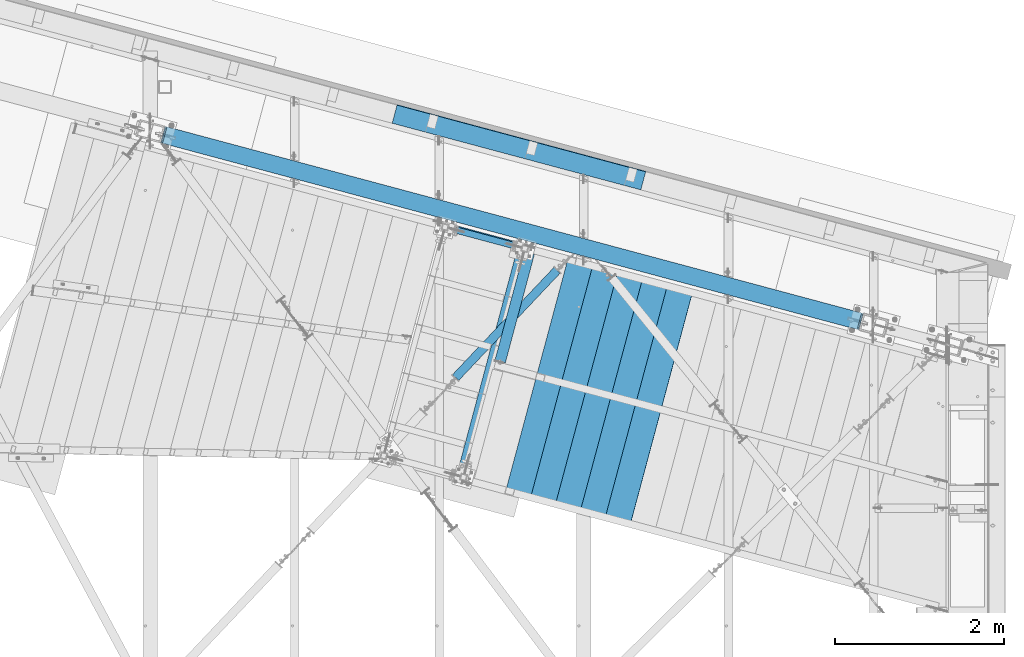
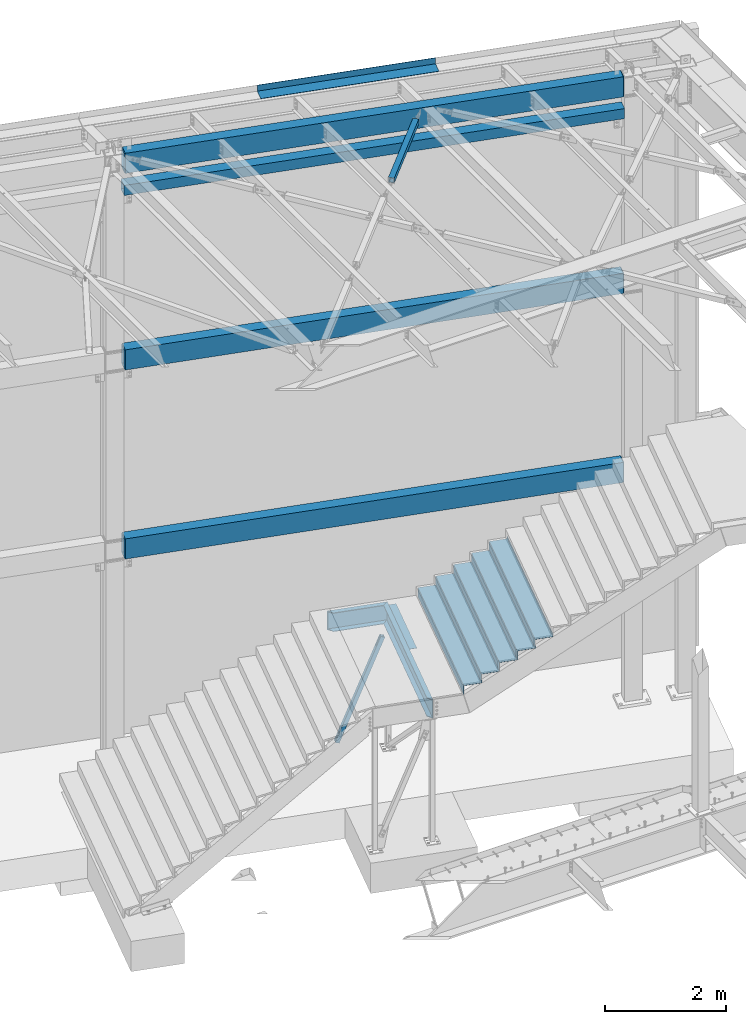
# One storey, part 1174 of 1763: 14 beams, 1 member, 9 elements without a shape of their own.
"""IFC2X3 building model written with IfcOpenShell, lengths in millimetres."""

from ifc_helpers import new_model, si_unit, frame, origin_with_axes, place, context, subcontext, project, spatial, faceted_brep, material, type_object, element, aggregate, save


model = new_model("IFC2X3")

# Units and contexts
model_context = context("Model", 3, precision=1e-05, world=origin_with_axes())
body_context = subcontext(model_context, "Body", "Model", "MODEL_VIEW")
ifc_project = project(units=[si_unit("LENGTHUNIT", "METRE", prefix="MILLI"), si_unit("AREAUNIT", "SQUARE_METRE"), si_unit("VOLUMEUNIT", "CUBIC_METRE"), si_unit("MASSUNIT", "GRAM", prefix="KILO"), si_unit("TIMEUNIT", "SECOND"), si_unit("PLANEANGLEUNIT", "RADIAN"), si_unit("SOLIDANGLEUNIT", "STERADIAN"), si_unit("THERMODYNAMICTEMPERATUREUNIT", "DEGREE_CELSIUS"), si_unit("LUMINOUSINTENSITYUNIT", "LUMEN")], contexts=[model_context])

# Site, building, storey
site_placement = place(None, origin_with_axes())
site = spatial("IfcSite", under=ifc_project, at=site_placement, CompositionType="ELEMENT")
building_placement = place(site_placement, origin_with_axes())
building = spatial("IfcBuilding", under=site, at=building_placement, Name="Undefined", CompositionType="ELEMENT")
storey_placement = place(building_placement, origin_with_axes())
storey = spatial("IfcBuildingStorey", under=building, at=storey_placement, Name="Undefined", CompositionType="ELEMENT", Elevation=0.0)

# Assembly, beam
assembly_1_placement = place(storey_placement, origin_with_axes())
assembly_1 = element("IfcElementAssembly", 1, at=assembly_1_placement, inside=storey, Name="BEAM", AssemblyPlace="NOTDEFINED", PredefinedType="RIGID_FRAME")
ifc_material_1 = material()
beam_type_1 = type_object("IfcBeamType", Name="HSS8X8X3/8", PredefinedType="NOTDEFINED")
beam_1_placement = place(assembly_1_placement, frame((-31109.3096174142, 64386.9589945275, 11699.875), z_axis=(0.0, 0.0, 1.0), x_axis=(0.965925826295336, -0.25881904507913, 0.0)))
beam_1 = element("IfcBeam", 2, at=beam_1_placement, type_object=beam_type_1, material=ifc_material_1, Name="BEAM", ObjectType="HSS8X8X3/8", context=body_context, shape_type="Brep", body=[
    faceted_brep([(152.404929528384, 92.0750000005864, -92.0750000000007), (152.404929527896, -92.0749999999898, -92.0750000000007), (8712.52908409735, -92.0749999837644, -92.0750000000007), (8712.52908409783, 92.0750000168191, -92.0750000000007), (152.404929527896, -92.0749999999898, 92.0750000000007), (8712.52908409735, -92.0749999837644, 92.0750000000007), (152.404929528384, 92.0750000005864, 92.0750000000007), (8712.52908409783, 92.0750000168191, 92.0750000000007), (152.404929528398, 101.600000000624, -101.6), (152.404929528398, 101.600000000624, 101.6), (8712.52908409786, 101.600000016842, 101.6), (8712.52908409786, 101.600000016842, -101.6), (152.404929527875, -101.60000000002, 101.6), (8712.52908409732, -101.59999998378, 101.6), (152.404929527875, -101.60000000002, -101.6), (8712.52908409732, -101.59999998378, -101.6)], [[[0, 1, 2, 3]], [[1, 4, 5, 2]], [[4, 6, 7, 5]], [[6, 0, 3, 7]], [[8, 9, 10, 11]], [[9, 12, 13, 10]], [[12, 14, 15, 13]], [[14, 8, 11, 15]], [[13, 15, 11, 10], [5, 7, 3, 2]], [[14, 12, 9, 8], [6, 4, 1, 0]]]),
])
aggregate(assembly_1, [beam_1])

assembly_2_placement = place(storey_placement, origin_with_axes())
assembly_2 = element("IfcElementAssembly", 3, at=assembly_2_placement, inside=storey, Name="BEAM", AssemblyPlace="NOTDEFINED", PredefinedType="RIGID_FRAME")
beam_type_2 = type_object("IfcBeamType", Name="HSS16X8X5/8", PredefinedType="NOTDEFINED")
beam_2_placement = place(assembly_2_placement, frame((-31109.3096174048, 64386.9589945249, 4470.4), z_axis=(0.0, 0.0, 1.0), x_axis=(0.965925826295336, -0.25881904507913, 0.0)))
beam_2 = element("IfcBeam", 4, at=beam_2_placement, type_object=beam_type_2, material=ifc_material_1, Name="BEAM", ObjectType="HSS16X8X5/8", context=body_context, shape_type="Brep", body=[
    faceted_brep([(8706.29922780173, 85.7250000167842, 187.325), (8706.29922780173, 85.7250000167842, -187.325), (8690.42422780702, 101.600000016799, -203.2), (8690.42422778126, 101.600000016799, 203.2), (8706.29922780129, -85.7249999837513, -187.325), (8690.42422779865, -101.599999983831, -203.2), (8706.29922779947, -85.7249999797496, 187.325000002187), (8690.42422778073, -101.599999983846, 203.200000000012), (176.102216332838, -101.599999999984, -203.2), (160.22721633505, -85.7249999999549, -187.325), (160.227216335486, 85.7250000005733, -187.325), (176.102216335254, 101.600000000661, -203.2), (176.102216340318, -101.600000008715, 203.200000006226), (160.22721633505, -85.7249999999549, 187.325), (176.102216355808, 101.600000000661, 203.2), (160.227216335486, 85.7250000005733, 187.325)], [[[0, 1, 2, 3]], [[4, 5, 2, 1]], [[6, 7, 5, 4]], [[8, 9, 10, 11]], [[12, 13, 9, 8]], [[14, 15, 13, 12]], [[13, 15, 0, 6]], [[9, 13, 6, 4]], [[10, 9, 4, 1]], [[15, 10, 1, 0]], [[14, 11, 10, 15]], [[11, 14, 3, 2]], [[8, 11, 2, 5]], [[12, 8, 5, 7]], [[14, 12, 7, 3]], [[0, 3, 7, 6]]]),
])
aggregate(assembly_2, [beam_2])

assembly_3_placement = place(storey_placement, origin_with_axes())
assembly_3 = element("IfcElementAssembly", 5, at=assembly_3_placement, inside=storey, Name="BEAM", AssemblyPlace="NOTDEFINED", PredefinedType="RIGID_FRAME")
beam_3_placement = place(assembly_3_placement, frame((-31109.3096174489, 64386.9589945368, 8280.4), z_axis=(0.0, 0.0, 1.0), x_axis=(0.965925826295336, -0.25881904507913, 0.0)))
beam_3 = element("IfcBeam", 6, at=beam_3_placement, type_object=beam_type_2, material=ifc_material_1, Name="BEAM", ObjectType="HSS16X8X5/8", context=body_context, shape_type="Brep", body=[
    faceted_brep([(8706.29922780173, 85.7250000167842, 187.325), (8706.29922780173, 85.7250000167842, -187.325), (8690.42422780702, 101.600000016799, -203.2), (8690.42422778126, 101.600000016799, 203.2), (8706.29922780129, -85.7249999837513, -187.325), (8690.42422779865, -101.599999983831, -203.2), (8706.29922779947, -85.7249999797496, 187.325000002187), (8690.42422778073, -101.599999983846, 203.200000000012), (176.102216332838, -101.599999999984, -203.2), (160.22721633505, -85.7249999999549, -187.325), (160.227216335486, 85.7250000005733, -187.325), (176.102216335254, 101.600000000661, -203.2), (176.102216340318, -101.600000008715, 203.200000006226), (160.22721633505, -85.7249999999549, 187.325), (176.102216355808, 101.600000000661, 203.2), (160.227216335486, 85.7250000005733, 187.325)], [[[0, 1, 2, 3]], [[4, 5, 2, 1]], [[6, 7, 5, 4]], [[8, 9, 10, 11]], [[12, 13, 9, 8]], [[14, 15, 13, 12]], [[13, 15, 0, 6]], [[9, 13, 6, 4]], [[10, 9, 4, 1]], [[15, 10, 1, 0]], [[14, 11, 10, 15]], [[11, 14, 3, 2]], [[8, 11, 2, 5]], [[12, 8, 5, 7]], [[14, 12, 7, 3]], [[0, 3, 7, 6]]]),
])
aggregate(assembly_3, [beam_3])

assembly_4_placement = place(storey_placement, origin_with_axes())
assembly_4 = element("IfcElementAssembly", 7, at=assembly_4_placement, inside=storey, Name="BEAM", AssemblyPlace="NOTDEFINED", PredefinedType="RIGID_FRAME")
beam_4_placement = place(assembly_4_placement, frame((-31109.3096174484, 64386.9589945366, 12242.8), z_axis=(0.0, 0.0, 1.0), x_axis=(0.965925826295336, -0.25881904507913, 0.0)))
beam_4 = element("IfcBeam", 8, at=beam_4_placement, type_object=beam_type_2, material=ifc_material_1, Name="BEAM", ObjectType="HSS16X8X5/8", context=body_context, shape_type="Brep", body=[
    faceted_brep([(8706.29429931691, 85.7250000167842, 187.325000000001), (8706.29429931691, 85.7250000167842, -187.325000000001), (8690.41929898654, 101.600000016806, -203.200000000001), (8690.41929916965, 101.600000016799, 203.200000000001), (8706.29429931647, -85.7249999837513, -187.325000000001), (8690.419298978, -101.599999983839, -203.200000000001), (8706.29429909084, -85.7249998677653, 187.32499989037), (8690.41929916909, -101.599999983882, 203.200000000046), (176.21743013963, -101.599999999984, -203.200000000001), (160.342430327146, -85.7249999999549, -187.325000000001), (160.342430327582, 85.7250000005733, -187.325000000001), (176.217430142162, 101.600000000653, -203.200000000001), (176.217430166151, -101.600000027807, 203.200000025201), (160.342430327146, -85.7249999999549, 187.325000000001), (176.217430219687, 101.600000000661, 203.200000000001), (160.342430327582, 85.7250000005733, 187.325000000001)], [[[0, 1, 2, 3]], [[4, 5, 2, 1]], [[6, 7, 5, 4]], [[8, 9, 10, 11]], [[12, 13, 9, 8]], [[14, 15, 13, 12]], [[13, 15, 0, 6]], [[9, 13, 6, 4]], [[10, 9, 4, 1]], [[15, 10, 1, 0]], [[14, 11, 10, 15]], [[11, 14, 3, 2]], [[8, 11, 2, 5]], [[12, 8, 5, 7]], [[14, 12, 7, 3]], [[0, 3, 7, 6]]]),
])
aggregate(assembly_4, [beam_4])

assembly_5_placement = place(storey_placement, origin_with_axes())
assembly_5 = element("IfcElementAssembly", 9, at=assembly_5_placement, inside=storey, Name="FRAME", AssemblyPlace="NOTDEFINED", PredefinedType="RIGID_FRAME")
ifc_material_2 = material(Name="STEEL/A36")
beam_type_3 = type_object("IfcBeamType", Name="L5X3X1/4", PredefinedType="NOTDEFINED")
beam_5_placement = place(assembly_5_placement, frame((-26967.7451795655, 61661.8263361301, 2590.8), z_axis=(0.965929517514198, -0.258805268869838, 0.0), x_axis=(0.258805268869838, 0.965929517514198, 0.0)))
beam_5 = element("IfcBeam", 10, at=beam_5_placement, type_object=beam_type_3, material=ifc_material_2, Name="ANGLE", ObjectType="L5X3X1/4", context=body_context, shape_type="Brep", body=[
    faceted_brep([(2.03726813197136e-10, 38.0999999999999, -63.5000000001164), (-2.03726813197136e-10, 38.0999999999999, 63.5000000001164), (1325.39221415859, 38.0999999999999, 63.4999999996871), (1325.39221415899, 38.0999999999999, -63.500000000553), (-2.03726813197136e-10, 31.75, 63.5000000001164), (1325.39221415859, 31.75, 63.4999999996871), (1.81898940354586e-10, 31.75, -57.1500000001106), (1325.39221415898, 31.75, -57.1500000005326), (1.81898940354586e-10, -38.0999999999999, -57.1500000001106), (1325.39221415898, -38.0999999999999, -57.1500000005326), (2.03726813197136e-10, -38.0999999999999, -63.5000000001164), (1325.39221415899, -38.0999999999999, -63.500000000553)], [[[0, 1, 2, 3]], [[1, 4, 5, 2]], [[4, 6, 7, 5]], [[6, 8, 9, 7]], [[8, 10, 11, 9]], [[10, 0, 3, 11]], [[5, 7, 9, 11, 3, 2]], [[10, 8, 6, 4, 1, 0]]]),
])

assembly_6_placement = place(storey_placement, origin_with_axes())
assembly_6 = element("IfcElementAssembly", 11, at=assembly_6_placement, inside=storey, Name="H. BRACE", AssemblyPlace="NOTDEFINED", PredefinedType="RIGID_FRAME")
beam_type_4 = type_object("IfcBeamType", Name="HSS4X4X3/8", PredefinedType="NOTDEFINED")
beam_6_placement = place(assembly_6_placement, frame((-26025.6786471991, 63024.8041814248, 12371.3875), z_axis=(0.0, 0.0, 1.0), x_axis=(-0.687068110981766, -0.726593015980713, 0.0)))
beam_6 = element("IfcBeam", 12, at=beam_6_placement, type_object=beam_type_4, material=ifc_material_1, Name="H. BRACE", ObjectType="HSS4X4X3/8", context=body_context, shape_type="Brep", body=[
    faceted_brep([(391.53019316982, 41.2749999986845, -41.2749999999996), (391.530193170245, -41.275000001202, -41.2749999999996), (2139.69905881955, -41.2750000068627, -41.2749999999996), (2139.69905881913, 41.2749999930238, -41.2749999999996), (391.530193170245, -41.275000001202, 41.2749999999996), (2139.69905881955, -41.2750000068627, 41.2749999999996), (391.53019316982, 41.2749999986845, 41.2749999999996), (2139.69905881913, 41.2749999930238, 41.2749999999996), (391.530193169772, 50.7999999986714, -50.7999999999993), (391.530193169772, 50.7999999986714, 50.7999999999993), (2139.69905881908, 50.799999993018, 50.7999999999993), (2139.69905881908, 50.799999993018, -50.7999999999993), (391.530193170289, -50.8000000011962, 50.7999999999993), (2139.6990588196, -50.8000000068423, 50.7999999999993), (391.530193170289, -50.8000000011962, -50.7999999999993), (2139.6990588196, -50.8000000068423, -50.7999999999993)], [[[0, 1, 2, 3]], [[1, 4, 5, 2]], [[4, 6, 7, 5]], [[6, 0, 3, 7]], [[8, 9, 10, 11]], [[9, 12, 13, 10]], [[12, 14, 15, 13]], [[14, 8, 11, 15]], [[13, 15, 11, 10], [5, 7, 3, 2]], [[14, 12, 9, 8], [6, 4, 1, 0]]]),
])
aggregate(assembly_6, [beam_6])

assembly_7_placement = place(storey_placement, origin_with_axes())
assembly_7 = element("IfcElementAssembly", 13, at=assembly_7_placement, inside=storey, Name="BEAM", AssemblyPlace="NOTDEFINED", PredefinedType="RIGID_FRAME")
beam_type_5 = type_object("IfcBeamType", PredefinedType="NOTDEFINED")
beam_7_placement = place(assembly_7_placement, frame((-26774.5380531226, 64086.7495871446, 12449.175), z_axis=(-0.965925827679309, 0.258819039914073, 0.0), x_axis=(0.258819045079128, 0.965925826295336, 0.0)))
beam_7 = element("IfcBeam", 14, at=beam_7_placement, type_object=beam_type_5, material=ifc_material_2, Name="BENT_PLATE", context=body_context, shape_type="Brep", body=[
    faceted_brep([(0.0, -3.17499999999927, -1523.99999999999), (0.0, -3.17499999999927, 1524.0), (0.0, 3.17499999999927, 1524.0), (0.0, 3.17499999999927, -1523.99999999999), (228.599995165183, 3.17499993969795, 1523.99999998704), (228.599994834185, 3.17499994154787, -1524.00000000063), (222.249995293445, -3.17500005680085, -1524.00000000046), (222.249995624443, -3.17500005865077, 1523.99999998722), (228.599994977769, -123.824999999819, 1524.000000004), (228.599994986405, -123.824999999819, -1524.00000000269), (222.249994977741, -123.824999999819, 1524.00000000397), (222.249994986378, -123.824999999819, -1524.00000000271)], [[[0, 1, 2, 3]], [[3, 2, 4, 5]], [[1, 0, 6, 7]], [[5, 4, 8, 9]], [[4, 2, 1, 7, 10, 8]], [[7, 6, 11, 10]], [[6, 0, 3, 5, 9, 11]], [[10, 11, 9, 8]]]),
])
aggregate(assembly_7, [beam_7])

# Beam
beam_type_6 = type_object("IfcBeamType", Name="C15X33.9", PredefinedType="NOTDEFINED")
beam_8_placement = place(assembly_5_placement, frame((-26368.1405581117, 62924.2356163714, 2438.40000001201), z_axis=(0.0, 0.0, -1.0), x_axis=(-0.965913267114846, 0.258865912030774, 0.0)))
beam_8 = element("IfcBeam", 15, at=beam_8_placement, type_object=beam_type_6, material=ifc_material_2, Name="FRAME", ObjectType="C15X33.9", context=body_context, shape_type="Brep", body=[
    faceted_brep([(315.850598956946, 42.8624999998137, -190.5), (315.850598956946, 42.8624999998137, 190.5), (1342.96309901459, 42.8624999991662, 190.5), (1342.96309901459, 42.8624999991662, -190.5), (401.57559901382, -42.862500000243, 190.5), (1257.23809907145, -42.8625000007742, 190.5), (401.57559901382, -42.862500000243, 181.7658925), (1257.23809907145, -42.8625000007742, 181.7658925), (325.37559896327, 33.337499999805, 169.0709725), (1333.4380990209, 33.3374999991793, 169.0709725), (325.37559896327, 33.337499999805, -169.0709725), (1333.4380990209, 33.3374999991793, -169.0709725), (401.57559901382, -42.862500000243, -181.7658925), (1257.23809907145, -42.8625000007742, -181.7658925), (401.57559901382, -42.862500000243, -190.5), (1257.23809907145, -42.8625000007742, -190.5)], [[[0, 1, 2, 3]], [[1, 4, 5, 2]], [[4, 6, 7, 5]], [[6, 8, 9, 7]], [[8, 10, 11, 9]], [[10, 12, 13, 11]], [[12, 14, 15, 13]], [[14, 0, 3, 15]], [[5, 7, 9, 11, 13, 15, 3, 2]], [[14, 12, 10, 8, 6, 4, 1, 0]]]),
])

beam_9_placement = place(assembly_5_placement, frame((-26716.6146878157, 63009.6748838013, 2438.40000002807), z_axis=(0.0, 0.0, 1.0), x_axis=(-0.258865912030778, -0.965913267114844, 3.00823476209188e-08)))
beam_9 = element("IfcBeam", 16, at=beam_9_placement, type_object=beam_type_6, material=ifc_material_2, Name="FRAME", ObjectType="C15X33.9", context=body_context, shape_type="Brep", body=[
    faceted_brep([(-50.5436514046814, 42.8624999999665, -190.5), (-50.5436514046814, 42.8624999999665, 190.5), (2870.4656608373, 42.8625000017928, 190.5), (2870.4656608373, 42.8625000017928, -190.5), (35.1813485384482, -42.8624999999738, 190.5), (2784.74066078044, -42.8624999982567, 190.5), (35.1813485384482, -42.8624999999738, 181.7658925), (2784.74066078044, -42.8624999982567, 181.7658925), (-41.0186514109955, 33.3374999999724, 169.0709725), (2860.94066083099, 33.3375000017913, 169.0709725), (-41.0186514109955, 33.3374999999724, -169.0709725), (2860.94066083099, 33.3375000017913, -169.0709725), (35.1813485384482, -42.8624999999738, -181.7658925), (2784.74066078044, -42.8624999982567, -181.7658925), (35.1813485384482, -42.8624999999738, -190.5), (2784.74066078044, -42.8624999982567, -190.5)], [[[0, 1, 2, 3]], [[1, 4, 5, 2]], [[4, 6, 7, 5]], [[6, 8, 9, 7]], [[8, 10, 11, 9]], [[10, 12, 13, 11]], [[12, 14, 15, 13]], [[14, 0, 3, 15]], [[5, 7, 9, 11, 13, 15, 3, 2]], [[14, 12, 10, 8, 6, 4, 1, 0]]]),
])

aggregate(assembly_5, [beam_5, beam_8, beam_9])

# Assembly, member
assembly_8_placement = place(storey_placement, origin_with_axes())
assembly_8 = element("IfcElementAssembly", 17, at=assembly_8_placement, inside=storey, Name="BRACE", AssemblyPlace="NOTDEFINED", PredefinedType="RIGID_FRAME")
member_type = type_object("IfcMemberType", Name="HSS3X3X1/4", PredefinedType="NOTDEFINED")
member_placement = place(assembly_8_placement, frame((-27619.8997057889, 63251.3629503325, -254.000000011885), z_axis=(-0.899634444304772, 0.241103108081683, 0.364042796788778), x_axis=(0.35163376710363, -0.0942382710277749, 0.931382221274491)))
member = element("IfcMember", 18, at=member_placement, type_object=member_type, material=ifc_material_1, Name="BRACE", ObjectType="HSS3X3X1/4", context=body_context, shape_type="Brep", body=[
    faceted_brep([(2414.45434493126, 6.35000002325251, 38.100000002516), (2208.07933722691, 6.34999998997228, 38.1000000022977), (2208.0793372269, 6.34999998371495, 31.7500000022992), (2414.45434492988, 6.35000001702429, 31.7500000025175), (2205.64929746808, 5.86663502834563, 38.1000000022977), (2205.64929746807, 5.86663502208103, 31.7500000023065), (2203.58920923428, 4.49012807789404, 38.1000000022905), (2203.58920923427, 4.49012807162944, 31.7500000022992), (2202.21270228434, 2.43003984375537, 38.1000000022905), (2202.21270228433, 2.43003983749804, 31.7500000022992), (2201.72933732329, 1.01557816378772e-07, 38.1000000022977), (2201.72933732328, 9.53004928305745e-08, 31.7500000022847), (2202.21270228479, -2.43003965742537, 38.1000000022832), (2202.21270228477, -2.43003966369724, 31.7500000022919), (2203.58920923519, -4.4901278913967, 38.1000000022905), (2203.58920923518, -4.49012789765402, 31.7500000022847), (2205.64929746938, -5.86663484146266, 38.1000000022905), (2205.64929746937, -5.86663484771998, 31.7500000022919), (2208.07933722844, -6.34999980255816, 38.1000000022905), (2208.07933722843, -6.34999980881548, 31.7500000022919), (2414.4543449323, -6.34999978563428, 38.1000000025088), (2414.45434493092, -6.34999979185523, 31.7500000025102), (2414.45434491601, 6.34999995474936, -31.7499999974898), (2208.07933722681, 6.34999992109078, -31.7499999977008), (2208.0793372268, 6.34999991484074, -38.0999999976993), (2414.45434491462, 6.34999994852114, -38.0999999974811), (2205.64929746798, 5.86663495945686, -31.7499999977008), (2205.64929746797, 5.86663495318498, -38.0999999977066), (2203.58920923419, 4.49012800901255, -31.7499999977008), (2203.58920923418, 4.49012800275523, -38.0999999976993), (2202.21270228424, 2.43003977487388, -31.7499999977081), (2202.21270228424, 2.43003976861655, -38.0999999977066), (2201.7293373232, 3.26763256452978e-08, -31.7499999977153), (2201.72933732319, 2.64190020971e-08, -38.0999999977139), (2202.21270228469, -2.43003972630686, -31.7499999977081), (2202.21270228468, -2.43003973256418, -38.0999999977066), (2203.58920923509, -4.49012796027819, -31.7499999977081), (2203.58920923509, -4.49012796654279, -38.0999999977139), (2205.64929746928, -5.86663491035142, -31.7499999977081), (2205.64929746927, -5.86663491660875, -38.0999999977066), (2208.07933722834, -6.34999987143965, -31.7499999977008), (2208.07933722833, -6.34999987770425, -38.0999999976993), (2414.45434491705, -6.34999985413015, -31.7499999974898), (2414.45434491566, -6.34999986035837, -38.0999999974883), (272.045029819303, 31.7500000001455, 31.7500000002983), (272.045029805433, 31.7499999999491, -31.7499999997017), (2414.45434491393, 31.7500000004147, -31.7499999974752), (2414.4543449278, 31.7500000006112, 31.750000002532), (2414.454344933, -31.749999999367, 31.7500000025029), (272.045029824505, -31.7499999998254, 31.7500000002692), (272.045029822426, -6.34999976371182, 31.7500000002765), (478.420036850601, -6.34999974640959, 31.7500000004948), (480.850076609582, -5.86663478490664, 31.750000000502), (482.910164843544, -4.49012783449871, 31.750000000502), (484.286671793616, -2.43003960030182, 31.750000000502), (484.77003675471, 1.58768671099097e-07, 31.750000000502), (484.286671793172, 2.43003993458115, 31.7500000005093), (482.910164842637, 4.49012816861068, 31.7500000005093), (480.850076608282, 5.86663511865481, 31.750000000502), (478.420036849073, 6.35000007959752, 31.7500000004948), (272.045029821385, 6.35000004598987, 31.750000000291), (272.045029810639, -31.7500000000218, -31.7499999997308), (2414.45434491913, -31.7499999995634, -31.7499999975043), (272.045029807516, 6.34999998371495, -31.749999999709), (478.420036848982, 6.35000001698063, -31.749999999498), (480.850076608189, 5.86663505603065, -31.749999999498), (482.910164842544, 4.49012810599379, -31.749999999498), (484.286671793079, 2.43003987196425, -31.7499999994907), (484.770036754617, 9.61445039138198e-08, -31.7499999994907), (484.286671793523, -2.43003966291872, -31.749999999498), (482.910164843453, -4.4901278971156, -31.749999999498), (480.850076609491, -5.8666348475308, -31.749999999498), (478.420036850512, -6.34999980903376, -31.7499999995052), (272.045029808558, -6.34999982599402, -31.7499999997162), (272.04502980613, 6.34999997748673, -38.0999999997148), (478.420036848971, 6.35000001072331, -38.0999999994965), (480.850076608182, 5.86663504976605, -38.0999999994965), (482.910164842537, 4.49012809972919, -38.0999999994965), (484.286671793068, 2.43003986569965, -38.0999999994965), (484.770036754606, 8.9887180365622e-08, -38.0999999994965), (484.286671793514, -2.43003966917604, -38.0999999994965), (482.910164843444, -4.4901279033802, -38.0999999994965), (480.850076609482, -5.8666348537954, -38.0999999995038), (478.420036850501, -6.34999981529836, -38.0999999995038), (272.045029807168, -6.34999983221496, -38.0999999997221), (272.045029809769, -38.1000000000422, -38.0999999997366), (272.045029826411, -38.0999999998021, 38.1000000002605), (272.04502982381, -6.34999975747633, 38.1000000002823), (478.420036850614, -6.34999974013772, 38.1000000004933), (480.850076609593, -5.86663477865659, 38.1000000004933), (482.910164843555, -4.49012782823411, 38.1000000004933), (484.286671793623, -2.4300395940445, 38.1000000004933), (484.770036754719, 1.65025994647294e-07, 38.1000000005079), (484.286671793181, 2.43003994084575, 38.1000000005006), (482.910164842646, 4.490128174868, 38.1000000005006), (480.850076608293, 5.86663512491214, 38.1000000005006), (478.420036849082, 6.35000008586212, 38.1000000005006), (272.045029822772, 6.35000005221809, 38.1000000002823), (272.045029820169, 38.1000000001659, 38.1000000003041), (272.045029803527, 38.0999999999258, -38.0999999997002), (2414.45434492866, 38.100000000617, 38.1000000025306), (2414.45434491202, 38.1000000003842, -38.0999999974665), (2414.45434491826, -38.0999999995838, -38.0999999974956), (2414.45434493491, -38.099999999351, 38.1000000024942)], [[[0, 1, 2, 3]], [[4, 5, 2, 1]], [[6, 7, 5, 4]], [[8, 9, 7, 6]], [[10, 11, 9, 8]], [[12, 13, 11, 10]], [[14, 15, 13, 12]], [[16, 17, 15, 14]], [[18, 19, 17, 16]], [[20, 21, 19, 18]], [[22, 23, 24, 25]], [[26, 27, 24, 23]], [[28, 29, 27, 26]], [[30, 31, 29, 28]], [[32, 33, 31, 30]], [[34, 35, 33, 32]], [[36, 37, 35, 34]], [[38, 39, 37, 36]], [[40, 41, 39, 38]], [[42, 43, 41, 40]], [[44, 45, 46, 47]], [[48, 49, 50, 51, 52, 53, 54, 55, 56, 57, 58, 59, 60, 44, 47, 3, 2, 5, 7, 9, 11, 13, 15, 17, 19, 21]], [[61, 49, 48, 62]], [[38, 36, 34, 32, 30, 28, 26, 23, 22, 46, 45, 63, 64, 65, 66, 67, 68, 69, 70, 71, 72, 73, 61, 62, 42, 40]], [[63, 74, 75, 64]], [[64, 75, 76, 65]], [[65, 76, 77, 66]], [[66, 77, 78, 67]], [[67, 78, 79, 68]], [[68, 79, 80, 69]], [[69, 80, 81, 70]], [[70, 81, 82, 71]], [[71, 82, 83, 72]], [[72, 83, 84, 73]], [[49, 61, 73, 84, 85, 86, 87, 50]], [[88, 51, 50, 87]], [[89, 52, 51, 88]], [[90, 53, 52, 89]], [[91, 54, 53, 90]], [[92, 55, 54, 91]], [[93, 56, 55, 92]], [[94, 57, 56, 93]], [[95, 58, 57, 94]], [[96, 59, 58, 95]], [[97, 60, 59, 96]], [[98, 99, 74, 63, 45, 44, 60, 97]], [[99, 98, 100, 101]], [[47, 46, 22, 25, 101, 100, 0, 3]], [[102, 85, 84, 83, 82, 81, 80, 79, 78, 77, 76, 75, 74, 99, 101, 25, 24, 27, 29, 31, 33, 35, 37, 39, 41, 43]], [[86, 85, 102, 103]], [[16, 14, 12, 10, 8, 6, 4, 1, 0, 100, 98, 97, 96, 95, 94, 93, 92, 91, 90, 89, 88, 87, 86, 103, 20, 18]], [[103, 102, 43, 42, 62, 48, 21, 20]]]),
])
aggregate(assembly_8, [member])

# Assembly, beams
assembly_9_placement = place(storey_placement, origin_with_axes())
assembly_9 = element("IfcElementAssembly", 19, at=assembly_9_placement, inside=storey, Name="STRINGER", AssemblyPlace="NOTDEFINED", PredefinedType="RIGID_FRAME")
beam_type_7 = type_object("IfcBeamType", PredefinedType="NOTDEFINED")
beam_10_placement = place(assembly_9_placement, frame((-25057.6710388289, 61105.4306051707, 3575.04999694859), z_axis=(-0.258865912030778, -0.965913267114844, 3.00823476209188e-08), x_axis=(0.0, 0.0, -1.0)))
beam_10 = element("IfcBeam", 20, at=beam_10_placement, type_object=beam_type_7, material=ifc_material_2, Name="BENT_PLATE", context=body_context, shape_type="Brep", body=[
    faceted_brep([(1.9117578631267e-09, -1.5875000009255, -1460.49999999993), (-1.18325260700658e-09, -1.58749999909924, 1460.49999999992), (-1.9117578631267e-09, 1.58750000090367, 1460.49999999991), (1.18234311230481e-09, 1.58749999907741, -1460.49999999993), (50.7999999972071, 1.58750001260341, 1460.50000000007), (50.800000002233, 1.58750001077715, -1460.49999999979), (47.6250000029295, -1.58749998995336, -1460.4999999998), (47.6249999979027, -1.58749998812709, 1460.50000000005), (50.8000000657603, -306.387503397986, 1460.50000000045), (50.8000000687034, -306.387503401733, -1460.49999999939), (47.6250000693999, -309.562503402434, -1460.4999999994), (47.6250000664559, -309.562503398687, 1460.50000000045), (222.250000065187, -306.387503360114, 1460.50000000094), (222.250000068131, -306.387503363934, -1460.49999999891), (222.250000065887, -309.562503360117, 1460.50000000094), (222.250000068831, -309.562503363937, -1460.4999999989)], [[[0, 1, 2, 3]], [[3, 2, 4, 5]], [[1, 0, 6, 7]], [[5, 4, 8, 9]], [[7, 6, 10, 11]], [[9, 8, 12, 13]], [[8, 4, 2, 1, 7, 11, 14, 12]], [[11, 10, 15, 14]], [[10, 6, 0, 3, 5, 9, 13, 15]], [[14, 15, 13, 12]]]),
])
beam_11_placement = place(assembly_9_placement, frame((-25352.0777587397, 61184.2013229867, 3397.25000915562), z_axis=(-0.258865912030778, -0.965913267114844, 3.00823476209188e-08), x_axis=(0.0, 0.0, -1.0)))
beam_11 = element("IfcBeam", 21, at=beam_11_placement, type_object=beam_type_7, material=ifc_material_2, Name="BENT_PLATE", context=body_context, shape_type="Brep", body=[
    faceted_brep([(1.9117578631267e-09, -1.5875000009255, -1460.49999999993), (-1.18325260700658e-09, -1.58749999909924, 1460.49999999992), (-1.9117578631267e-09, 1.58750000090367, 1460.49999999991), (1.18234311230481e-09, 1.58749999907741, -1460.49999999993), (50.7999999972071, 1.58750001260341, 1460.50000000007), (50.800000002233, 1.58750001077715, -1460.49999999979), (47.6250000029295, -1.58749998995336, -1460.4999999998), (47.6249999979027, -1.58749998812709, 1460.50000000005), (50.8000000657603, -306.387503397986, 1460.50000000045), (50.8000000687034, -306.387503401733, -1460.49999999939), (47.6250000693999, -309.562503402434, -1460.4999999994), (47.6250000664559, -309.562503398687, 1460.50000000045), (222.250000065187, -306.387503360114, 1460.50000000094), (222.250000068131, -306.387503363934, -1460.49999999891), (222.250000065887, -309.562503360117, 1460.50000000094), (222.250000068831, -309.562503363937, -1460.4999999989)], [[[0, 1, 2, 3]], [[3, 2, 4, 5]], [[1, 0, 6, 7]], [[5, 4, 8, 9]], [[7, 6, 10, 11]], [[9, 8, 12, 13]], [[8, 4, 2, 1, 7, 11, 14, 12]], [[11, 10, 15, 14]], [[10, 6, 0, 3, 5, 9, 13, 15]], [[14, 15, 13, 12]]]),
])
beam_12_placement = place(assembly_9_placement, frame((-25646.4917770152, 61263.2352679725, 3219.45002136266), z_axis=(-0.258865912030778, -0.965913267114844, 3.00823476209188e-08), x_axis=(0.0, 0.0, -1.0)))
beam_12 = element("IfcBeam", 22, at=beam_12_placement, type_object=beam_type_7, material=ifc_material_2, Name="BENT_PLATE", context=body_context, shape_type="Brep", body=[
    faceted_brep([(1.9117578631267e-09, -1.5875000009255, -1460.49999999993), (-1.18325260700658e-09, -1.58749999909924, 1460.49999999992), (-1.9117578631267e-09, 1.58750000090367, 1460.49999999991), (1.18234311230481e-09, 1.58749999907741, -1460.49999999993), (50.7999999972071, 1.58750001260341, 1460.50000000007), (50.800000002233, 1.58750001077715, -1460.49999999979), (47.6250000029295, -1.58749998995336, -1460.4999999998), (47.6249999979027, -1.58749998812709, 1460.50000000005), (50.8000000657603, -306.387503397986, 1460.50000000045), (50.8000000687034, -306.387503401733, -1460.49999999939), (47.6250000693999, -309.562503402434, -1460.4999999994), (47.6250000664559, -309.562503398687, 1460.50000000045), (222.250000065187, -306.387503360114, 1460.50000000094), (222.250000068131, -306.387503363934, -1460.49999999891), (222.250000065887, -309.562503360117, 1460.50000000094), (222.250000068831, -309.562503363937, -1460.4999999989)], [[[0, 1, 2, 3]], [[3, 2, 4, 5]], [[1, 0, 6, 7]], [[5, 4, 8, 9]], [[7, 6, 10, 11]], [[9, 8, 12, 13]], [[8, 4, 2, 1, 7, 11, 14, 12]], [[11, 10, 15, 14]], [[10, 6, 0, 3, 5, 9, 13, 15]], [[14, 15, 13, 12]]]),
])
beam_13_placement = place(assembly_9_placement, frame((-25940.9021461083, 61342.1375993734, 3041.65000305211), z_axis=(-0.258865912030778, -0.965913267114844, 3.00823476209188e-08), x_axis=(0.0, 0.0, -1.0)))
beam_13 = element("IfcBeam", 23, at=beam_13_placement, type_object=beam_type_7, material=ifc_material_2, Name="BENT_PLATE", context=body_context, shape_type="Brep", body=[
    faceted_brep([(1.9117578631267e-09, -1.5875000009255, -1460.49999999993), (-1.18325260700658e-09, -1.58749999909924, 1460.49999999992), (-1.9117578631267e-09, 1.58750000090367, 1460.49999999991), (1.18234311230481e-09, 1.58749999907741, -1460.49999999993), (50.7999999972071, 1.58750001260341, 1460.50000000007), (50.800000002233, 1.58750001077715, -1460.49999999979), (47.6250000029295, -1.58749998995336, -1460.4999999998), (47.6249999979027, -1.58749998812709, 1460.50000000005), (50.8000000657603, -306.387503397986, 1460.50000000045), (50.8000000687034, -306.387503401733, -1460.49999999939), (47.6250000693999, -309.562503402434, -1460.4999999994), (47.6250000664559, -309.562503398687, 1460.50000000045), (222.250000065187, -306.387503360114, 1460.50000000094), (222.250000068131, -306.387503363934, -1460.49999999891), (222.250000065887, -309.562503360117, 1460.50000000094), (222.250000068831, -309.562503363937, -1460.4999999989)], [[[0, 1, 2, 3]], [[3, 2, 4, 5]], [[1, 0, 6, 7]], [[5, 4, 8, 9]], [[7, 6, 10, 11]], [[9, 8, 12, 13]], [[8, 4, 2, 1, 7, 11, 14, 12]], [[11, 10, 15, 14]], [[10, 6, 0, 3, 5, 9, 13, 15]], [[14, 15, 13, 12]]]),
])
beam_type_8 = type_object("IfcBeamType", PredefinedType="NOTDEFINED")
beam_14_placement = place(assembly_9_placement, frame((-26235.3125151743, 61421.0399308663, 2863.85000000285), z_axis=(-0.258865912030778, -0.965913267114844, 3.00823476209188e-08), x_axis=(0.0, 0.0, -1.0)))
beam_14 = element("IfcBeam", 24, at=beam_14_placement, type_object=beam_type_8, material=ifc_material_2, Name="BENT_PLATE", context=body_context, shape_type="Brep", body=[
    faceted_brep([(1.9117578631267e-09, -1.5875000009255, -1460.49999999993), (-1.18325260700658e-09, -1.58749999909924, 1460.49999999992), (-1.9117578631267e-09, 1.58750000090367, 1460.49999999991), (1.18234311230481e-09, 1.58749999907741, -1460.49999999993), (50.7999999972071, 1.58750001260341, 1460.50000000007), (50.800000002233, 1.58750001077715, -1460.49999999979), (47.6250000029295, -1.58749998995336, -1460.4999999998), (47.6249999979027, -1.58749998812709, 1460.50000000005), (50.8000000657603, -306.387503397986, 1460.50000000045), (50.8000000687034, -306.387503401733, -1460.49999999939), (47.6250000693999, -309.562503402434, -1460.4999999994), (47.6250000664559, -309.562503398687, 1460.50000000045), (230.187500065188, -306.38750335644, 1460.50000000428), (230.187500068133, -306.387503361519, -1460.50000000279), (230.187500065887, -309.562503356436, 1460.50000000429), (230.187500068832, -309.562503361514, -1460.50000000279)], [[[0, 1, 2, 3]], [[3, 2, 4, 5]], [[1, 0, 6, 7]], [[5, 4, 8, 9]], [[7, 6, 10, 11]], [[9, 8, 12, 13]], [[8, 4, 2, 1, 7, 11, 14, 12]], [[11, 10, 15, 14]], [[10, 6, 0, 3, 5, 9, 13, 15]], [[14, 15, 13, 12]]]),
])
aggregate(assembly_9, [beam_10, beam_11, beam_12, beam_13, beam_14])

save(model, "model.ifc")
